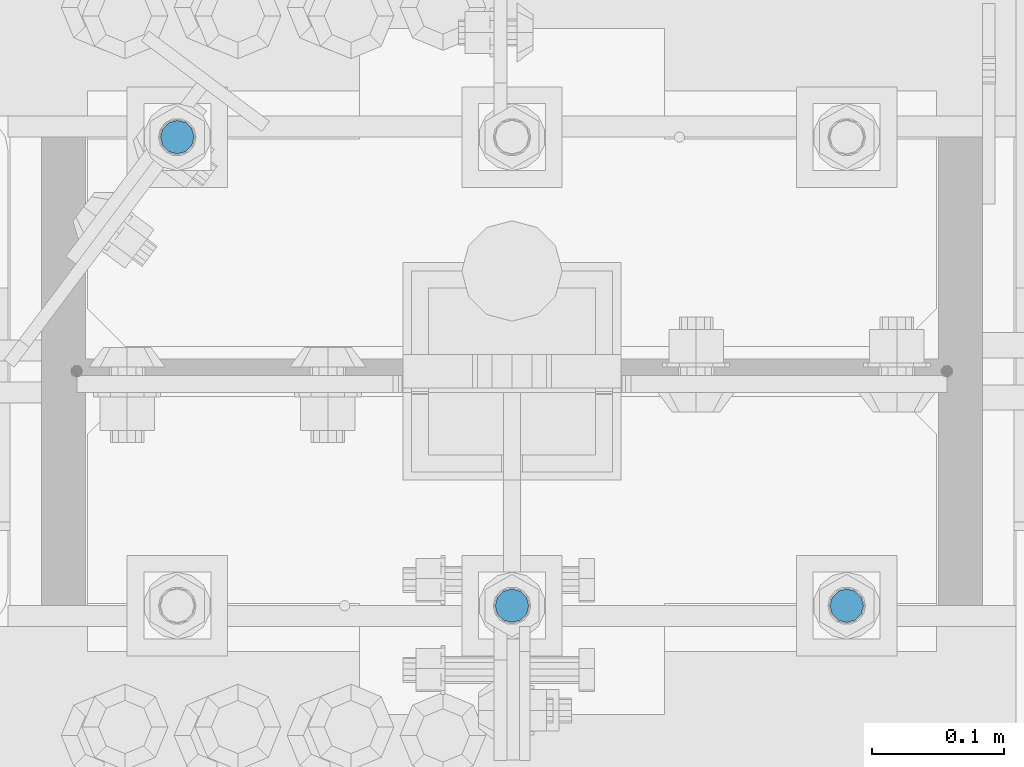
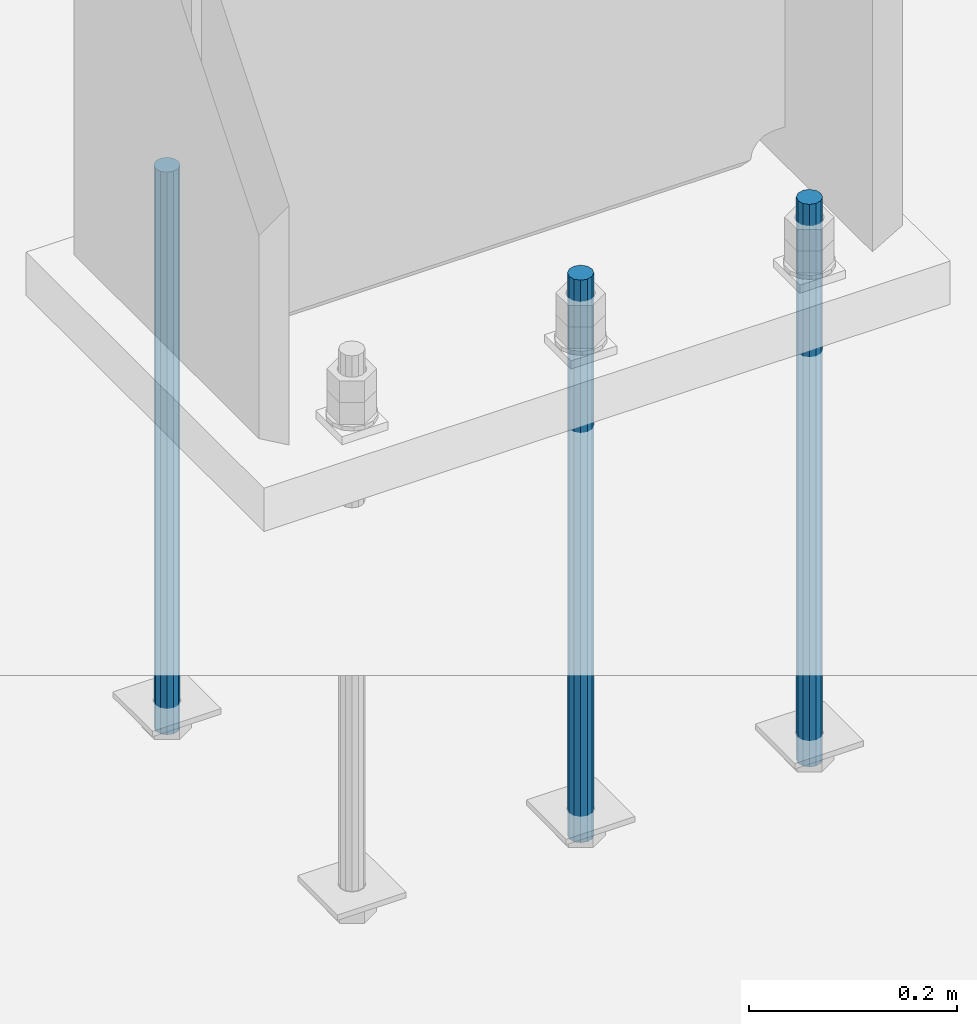
# One storey, part 958 of 1763: 3 columns, 1 element without a shape of its own.
"""IFC2X3 building model written with IfcOpenShell, lengths in millimetres."""

from ifc_helpers import new_model, si_unit, frame, origin_with_axes, place, context, subcontext, project, spatial, faceted_brep, material, type_object, element, aggregate, save


model = new_model("IFC2X3")

# Units and contexts
model_context = context("Model", 3, precision=1e-05, world=origin_with_axes())
body_context = subcontext(model_context, "Body", "Model", "MODEL_VIEW")
ifc_project = project(units=[si_unit("LENGTHUNIT", "METRE", prefix="MILLI"), si_unit("AREAUNIT", "SQUARE_METRE"), si_unit("VOLUMEUNIT", "CUBIC_METRE"), si_unit("MASSUNIT", "GRAM", prefix="KILO"), si_unit("TIMEUNIT", "SECOND"), si_unit("PLANEANGLEUNIT", "RADIAN"), si_unit("SOLIDANGLEUNIT", "STERADIAN"), si_unit("THERMODYNAMICTEMPERATUREUNIT", "DEGREE_CELSIUS"), si_unit("LUMINOUSINTENSITYUNIT", "LUMEN")], contexts=[model_context])

# Site, building, storey
site_placement = place(None, origin_with_axes())
site = spatial("IfcSite", under=ifc_project, at=site_placement, CompositionType="ELEMENT")
building_placement = place(site_placement, origin_with_axes())
building = spatial("IfcBuilding", under=site, at=building_placement, Name="Undefined", CompositionType="ELEMENT")
storey_placement = place(building_placement, origin_with_axes())
storey = spatial("IfcBuildingStorey", under=building, at=storey_placement, Name="Undefined", CompositionType="ELEMENT", Elevation=0.0)

# Assembly, columns
assembly_placement = place(storey_placement, origin_with_axes())
assembly = element("IfcElementAssembly", 1, at=assembly_placement, inside=storey, Name="TEMPLATE", AssemblyPlace="NOTDEFINED", PredefinedType="RIGID_FRAME")
ifc_material = material(Name="STEEL/F1554-55")
column_type = type_object("IfcColumnType", PredefinedType="NOTDEFINED")
column_1_placement = place(assembly_placement, frame((-34695.8372736984, 51943.0, -126.999999999997), z_axis=(1.0, 0.0, 0.0), x_axis=(0.0, 0.0, -1.0)))
column_1 = element("IfcColumn", 2, at=column_1_placement, type_object=column_type, material=ifc_material, Name="ALL THREADED ROD", context=body_context, shape_type="Brep", body=[
    faceted_brep([(0.0, -12.6999999999971, -1.81898940354586e-12), (0.0, -10.9985226280623, -6.35000000000582), (660.399, -10.9985226280623, -6.35000000000582), (660.399, -12.6999999999971, 0.0), (0.0, -6.34999999999854, -10.9985226280696), (660.399, -6.34999999999854, -10.9985226280696), (3.63797880709171e-12, 0.0, -12.6999998092651), (660.399, 0.0, -12.6999999999971), (0.0, 6.34999999999854, -10.9985226280696), (660.399, 6.34999999999854, -10.9985226280696), (0.0, 10.9985226280623, -6.35000000000582), (660.399, 10.9985226280623, -6.35000000000582), (0.0, 12.6999999999971, -1.81898940354586e-12), (660.399, 12.6999999999971, 0.0), (0.0, 10.9985226280623, 6.35000000000582), (660.399, 10.9985226280623, 6.35000000000582), (0.0, 6.34999999999854, 10.9985226280696), (660.399, 6.34999999999854, 10.9985226280696), (-3.63797880709171e-12, 0.0, 12.6999998092651), (660.399, 0.0, 12.6999999999971), (0.0, -6.34999999999854, 10.9985226280696), (660.399, -6.34999999999854, 10.9985226280696), (0.0, -10.9985226280623, 6.35000000000582), (660.399, -10.9985226280623, 6.35000000000582)], [[[0, 1, 2, 3]], [[1, 4, 5, 2]], [[4, 6, 7, 5]], [[6, 8, 9, 7]], [[8, 10, 11, 9]], [[10, 12, 13, 11]], [[12, 14, 15, 13]], [[14, 16, 17, 15]], [[16, 18, 19, 17]], [[18, 20, 21, 19]], [[20, 22, 23, 21]], [[22, 0, 3, 23]], [[5, 7, 9, 11, 13, 15, 17, 19, 21, 23, 3, 2]], [[22, 20, 18, 16, 14, 12, 10, 8, 6, 4, 1, 0]]]),
])
column_2_placement = place(assembly_placement, frame((-34949.8372736984, 51943.0, -126.999999999997), z_axis=(1.0, 0.0, 0.0), x_axis=(0.0, 0.0, -1.0)))
column_2 = element("IfcColumn", 3, at=column_2_placement, type_object=column_type, material=ifc_material, Name="ALL THREADED ROD", context=body_context, shape_type="Brep", body=[
    faceted_brep([(0.0, -12.6999999999971, -1.81898940354586e-12), (0.0, -10.9985226280623, -6.35000000000582), (660.399, -10.9985226280623, -6.35000000000582), (660.399, -12.6999999999971, 0.0), (0.0, -6.34999999999854, -10.9985226280696), (660.399, -6.34999999999854, -10.9985226280696), (3.63797880709171e-12, 0.0, -12.6999998092651), (660.399, 0.0, -12.6999999999971), (0.0, 6.34999999999854, -10.9985226280696), (660.399, 6.34999999999854, -10.9985226280696), (0.0, 10.9985226280623, -6.35000000000582), (660.399, 10.9985226280623, -6.35000000000582), (0.0, 12.6999999999971, -1.81898940354586e-12), (660.399, 12.6999999999971, 0.0), (0.0, 10.9985226280623, 6.35000000000582), (660.399, 10.9985226280623, 6.35000000000582), (0.0, 6.34999999999854, 10.9985226280696), (660.399, 6.34999999999854, 10.9985226280696), (-3.63797880709171e-12, 0.0, 12.6999998092651), (660.399, 0.0, 12.6999999999971), (0.0, -6.34999999999854, 10.9985226280696), (660.399, -6.34999999999854, 10.9985226280696), (0.0, -10.9985226280623, 6.35000000000582), (660.399, -10.9985226280623, 6.35000000000582)], [[[0, 1, 2, 3]], [[1, 4, 5, 2]], [[4, 6, 7, 5]], [[6, 8, 9, 7]], [[8, 10, 11, 9]], [[10, 12, 13, 11]], [[12, 14, 15, 13]], [[14, 16, 17, 15]], [[16, 18, 19, 17]], [[18, 20, 21, 19]], [[20, 22, 23, 21]], [[22, 0, 3, 23]], [[5, 7, 9, 11, 13, 15, 17, 19, 21, 23, 3, 2]], [[22, 20, 18, 16, 14, 12, 10, 8, 6, 4, 1, 0]]]),
])
column_3_placement = place(assembly_placement, frame((-35203.8372736984, 52298.6, -126.999999999997), z_axis=(-1.0, 0.0, 0.0), x_axis=(0.0, 0.0, -1.0)))
column_3 = element("IfcColumn", 4, at=column_3_placement, type_object=column_type, material=ifc_material, Name="ALL THREADED ROD", context=body_context, shape_type="Brep", body=[
    faceted_brep([(0.0, -12.6999999999971, -1.81898940354586e-12), (0.0, -10.9985226280623, -6.35000000000582), (660.399, -10.9985226280623, -6.35000000000582), (660.399, -12.6999999999971, 0.0), (0.0, -6.34999999999854, -10.9985226280696), (660.399, -6.34999999999854, -10.9985226280696), (3.63797880709171e-12, 0.0, -12.6999998092651), (660.399, 0.0, -12.6999999999971), (0.0, 6.34999999999854, -10.9985226280696), (660.399, 6.34999999999854, -10.9985226280696), (0.0, 10.9985226280623, -6.35000000000582), (660.399, 10.9985226280623, -6.35000000000582), (0.0, 12.6999999999971, -1.81898940354586e-12), (660.399, 12.6999999999971, 0.0), (0.0, 10.9985226280623, 6.35000000000582), (660.399, 10.9985226280623, 6.35000000000582), (0.0, 6.34999999999854, 10.9985226280696), (660.399, 6.34999999999854, 10.9985226280696), (-3.63797880709171e-12, 0.0, 12.6999998092651), (660.399, 0.0, 12.6999999999971), (0.0, -6.34999999999854, 10.9985226280696), (660.399, -6.34999999999854, 10.9985226280696), (0.0, -10.9985226280623, 6.35000000000582), (660.399, -10.9985226280623, 6.35000000000582)], [[[0, 1, 2, 3]], [[1, 4, 5, 2]], [[4, 6, 7, 5]], [[6, 8, 9, 7]], [[8, 10, 11, 9]], [[10, 12, 13, 11]], [[12, 14, 15, 13]], [[14, 16, 17, 15]], [[16, 18, 19, 17]], [[18, 20, 21, 19]], [[20, 22, 23, 21]], [[22, 0, 3, 23]], [[5, 7, 9, 11, 13, 15, 17, 19, 21, 23, 3, 2]], [[22, 20, 18, 16, 14, 12, 10, 8, 6, 4, 1, 0]]]),
])
aggregate(assembly, [column_1, column_2, column_3])

save(model, "model.ifc")
